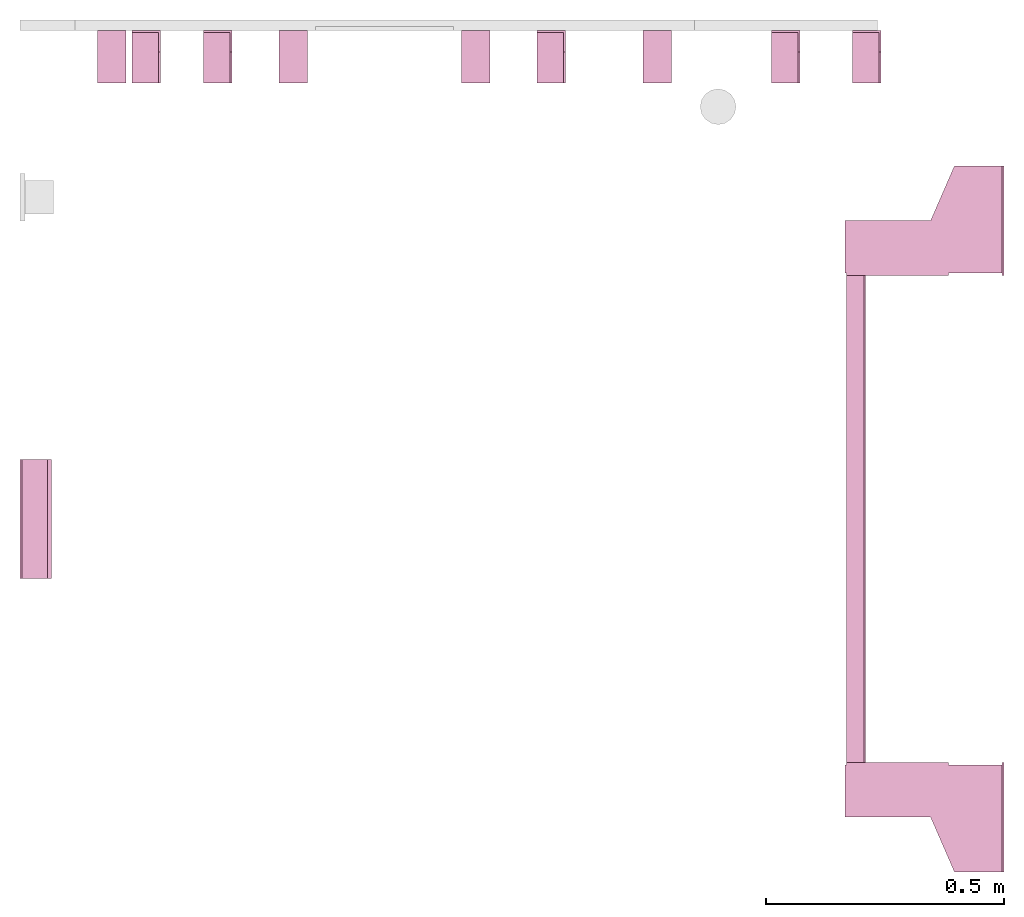
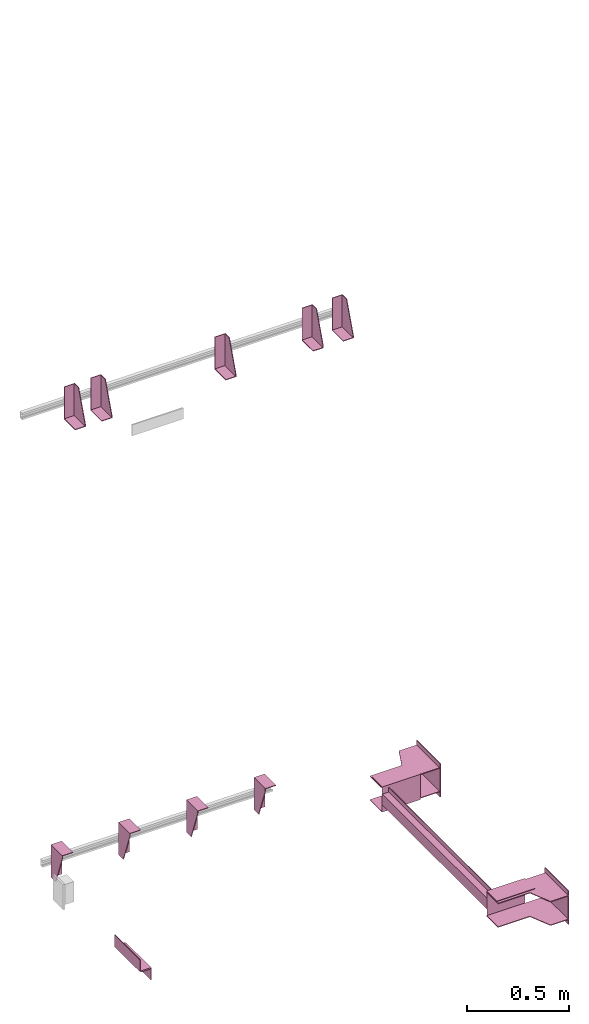
# One storey, part 3 of 3: 11 transport elements.
"""IFC4 building model written with IfcOpenShell, lengths in millimetres."""

from ifc_helpers import new_model, entity, si_unit, converted_unit, frame, origin_with_axes, place, context, subcontext, project, spatial, faceted_brep, element, save


model = new_model("IFC4")

# Units and contexts
context_of_model = context(None, 3, precision=0.01, world=origin_with_axes())
sub_context_1 = subcontext(context_of_model, None, None, "MODEL_VIEW")
sub_context_2 = subcontext(context_of_model, None, None, "MODEL_VIEW")
sub_context_3 = subcontext(context_of_model, None, None, "MODEL_VIEW")
sub_context_4 = subcontext(context_of_model, None, None, "MODEL_VIEW")
sub_context_5 = subcontext(context_of_model, None, None, "MODEL_VIEW")
sub_context_6 = subcontext(context_of_model, None, None, "MODEL_VIEW")
sub_context_7 = subcontext(context_of_model, None, None, "MODEL_VIEW")
sub_context_8 = subcontext(context_of_model, None, None, "MODEL_VIEW")
sub_context_9 = subcontext(context_of_model, None, None, "MODEL_VIEW")
sub_context_10 = subcontext(context_of_model, None, None, "MODEL_VIEW")
sub_context_11 = subcontext(context_of_model, None, None, "MODEL_VIEW")
ifc_project = project(units=[converted_unit("PLANEANGLEUNIT", "degree", entity("IfcPlaneAngleMeasure", 0.017453292519943), si_unit("PLANEANGLEUNIT", "RADIAN"), dimensions=[0, 0, 0, 0, 0, 0, 0]), si_unit("LENGTHUNIT", "METRE", prefix="MILLI"), si_unit("MASSUNIT", "GRAM", prefix="KILO"), converted_unit("TIMEUNIT", "year", entity("IfcTimeMeasure", 31557600.0), si_unit("TIMEUNIT", "SECOND"), dimensions=[0, 0, 1, 0, 0, 0, 0]), si_unit("THERMODYNAMICTEMPERATUREUNIT", "DEGREE_CELSIUS"), si_unit("AREAUNIT", "SQUARE_METRE"), si_unit("FORCEUNIT", "NEWTON"), si_unit("VOLUMEUNIT", "CUBIC_METRE"), si_unit("PRESSUREUNIT", "PASCAL"), si_unit("SOLIDANGLEUNIT", "STERADIAN")], contexts=[context_of_model])

# Site, building, storey
site = spatial("IfcSite", under=ifc_project)
building = spatial("IfcBuilding", under=site, Name="Document")
placement = place(None, origin_with_axes())
storey_placement = place(placement, frame((0.0, 0.0, -10200.0), z_axis=(0.0, 0.0, 1.0), x_axis=(1.0, 0.0, 0.0)))
storey = spatial("IfcBuildingStorey", under=building, at=storey_placement, Name="P1", Elevation=-10200.0)

# Transport elements
transport_element_1_placement = place(storey_placement, frame((2065.0, 1025.0, 0.0), z_axis=(0.0, 0.0, 1.0), x_axis=(0.0, 1.0, 0.0)))
element("IfcTransportElement", 1, at=transport_element_1_placement, inside=storey, PredefinedType="ELEVATOR", context=sub_context_1, shape_type="Brep", body=[
    faceted_brep([(-511.0, 331.0, 32.5), (511.0, 331.0, 32.5), (511.0, 331.0, -32.5), (-511.0, 331.0, -32.5), (511.0, 328.0, -29.5), (511.0, 328.0, 29.5), (-511.0, 328.0, 29.5), (-511.0, 328.0, -29.5), (511.0, 291.0, -32.5), (511.0, 291.0, -29.5), (-511.0, 291.0, -29.5), (-511.0, 291.0, -32.5), (511.0, 291.0, 29.5), (511.0, 291.0, 32.5), (-511.0, 291.0, 32.5), (-511.0, 291.0, 29.5)], [[[0, 1, 2, 3]], [[4, 5, 6, 7]], [[8, 9, 10, 11]], [[12, 13, 14, 15]], [[11, 10, 7, 6, 15, 14, 0, 3]], [[2, 1, 13, 12, 5, 4, 9, 8]], [[2, 8, 11, 3]], [[10, 9, 4, 7]], [[14, 13, 1, 0]], [[5, 12, 15, 6]]]),
    faceted_brep([(-511.0, 291.0, 59.5), (-511.0, 294.0, 59.5), (-511.0, 294.0, 32.5), (-511.0, 291.0, 32.5), (511.0, 291.0, 59.5), (511.0, 291.0, 32.5), (511.0, 294.0, 32.5), (511.0, 294.0, 59.5)], [[[0, 1, 2, 3]], [[4, 5, 6, 7]], [[0, 3, 5, 4]], [[3, 2, 6, 5]], [[2, 1, 7, 6]], [[1, 0, 4, 7]]]),
    faceted_brep([(-611.0, 331.0, -72.5), (-514.0, 331.0, -72.5), (-514.0, 331.0, 72.5), (-611.0, 331.0, 72.5), (-611.0, 331.0, 75.5), (-511.0, 331.0, 75.5), (-511.0, 331.0, -75.5), (-611.0, 331.0, -75.5), (-511.0, 116.0, -75.5), (-511.0, 116.0, 75.5), (-611.0, 116.0, 75.5), (-611.0, 116.0, 72.5), (-514.0, 116.0, 72.5), (-514.0, 116.0, -72.5), (-611.0, 116.0, -72.5), (-611.0, 116.0, -75.5)], [[[0, 1, 2, 3, 4, 5, 6, 7]], [[8, 9, 10, 11, 12, 13, 14, 15]], [[15, 14, 0, 7]], [[13, 12, 2, 1]], [[5, 9, 8, 6]], [[11, 10, 4, 3]], [[6, 8, 15, 7]], [[14, 13, 1, 0]], [[2, 12, 11, 3]], [[10, 9, 5, 4]]]),
    faceted_brep([(511.0, 331.0, 75.5), (611.0, 331.0, 75.5), (611.0, 331.0, 72.5), (514.0, 331.0, 72.5), (514.0, 331.0, -72.5), (611.0, 331.0, -72.5), (611.0, 331.0, -75.5), (511.0, 331.0, -75.5), (511.0, 116.0, -75.5), (611.0, 116.0, -75.5), (611.0, 116.0, -72.5), (514.0, 116.0, -72.5), (514.0, 116.0, 72.5), (611.0, 116.0, 72.5), (611.0, 116.0, 75.5), (511.0, 116.0, 75.5)], [[[0, 1, 2, 3, 4, 5, 6, 7]], [[8, 9, 10, 11, 12, 13, 14, 15]], [[8, 15, 0, 7]], [[3, 12, 11, 4]], [[5, 10, 9, 6]], [[1, 14, 13, 2]], [[6, 9, 8, 7]], [[11, 10, 5, 4]], [[15, 14, 1, 0]], [[2, 13, 12, 3]]]),
    faceted_brep([(-511.0, 291.0, -32.5), (-511.0, 294.0, -32.5), (-511.0, 294.0, -59.5), (-511.0, 291.0, -59.5), (511.0, 291.0, -32.5), (511.0, 291.0, -59.5), (511.0, 294.0, -59.5), (511.0, 294.0, -32.5)], [[[0, 1, 2, 3]], [[4, 5, 6, 7]], [[0, 3, 5, 4]], [[3, 2, 6, 5]], [[2, 1, 7, 6]], [[1, 0, 4, 7]]]),
    faceted_brep([(-626.0, 334.0, 72.5), (-516.0, 334.0, 72.5), (-516.0, 334.0, 68.5), (-626.0, 334.0, 68.5), (-516.0, 4.0, 68.5), (-516.0, 4.0, 72.5), (-741.0, 4.0, 72.5), (-741.0, 4.0, 68.5), (-741.0, 104.0, 72.5), (-626.0, 154.0, 72.5), (-626.0, 154.0, 68.5), (-741.0, 104.0, 68.5)], [[[0, 1, 2, 3]], [[4, 5, 6, 7]], [[8, 9, 10, 11]], [[10, 9, 0, 3]], [[1, 5, 4, 2]], [[7, 6, 8, 11]], [[2, 4, 7, 11, 10, 3]], [[9, 8, 6, 5, 1, 0]]]),
    faceted_brep([(516.0, 334.0, 72.5), (626.0, 334.0, 72.5), (626.0, 334.0, 68.5), (516.0, 334.0, 68.5), (741.0, 4.0, 68.5), (741.0, 4.0, 72.5), (516.0, 4.0, 72.5), (516.0, 4.0, 68.5), (626.0, 154.0, 72.5), (741.0, 104.0, 72.5), (741.0, 104.0, 68.5), (626.0, 154.0, 68.5)], [[[0, 1, 2, 3]], [[4, 5, 6, 7]], [[8, 9, 10, 11]], [[7, 6, 0, 3]], [[1, 8, 11, 2]], [[9, 5, 4, 10]], [[2, 11, 10, 4, 7, 3]], [[6, 5, 9, 8, 1, 0]]]),
    faceted_brep([(516.0, 334.0, -68.5), (626.0, 334.0, -68.5), (626.0, 334.0, -72.5), (516.0, 334.0, -72.5), (741.0, 4.0, -72.5), (741.0, 4.0, -68.5), (516.0, 4.0, -68.5), (516.0, 4.0, -72.5), (626.0, 154.0, -68.5), (741.0, 104.0, -68.5), (741.0, 104.0, -72.5), (626.0, 154.0, -72.5)], [[[0, 1, 2, 3]], [[4, 5, 6, 7]], [[8, 9, 10, 11]], [[7, 6, 0, 3]], [[1, 8, 11, 2]], [[9, 5, 4, 10]], [[2, 11, 10, 4, 7, 3]], [[6, 5, 9, 8, 1, 0]]]),
    faceted_brep([(-626.0, 334.0, -68.5), (-516.0, 334.0, -68.5), (-516.0, 334.0, -72.5), (-626.0, 334.0, -72.5), (-516.0, 4.0, -72.5), (-516.0, 4.0, -68.5), (-741.0, 4.0, -68.5), (-741.0, 4.0, -72.5), (-741.0, 104.0, -68.5), (-626.0, 154.0, -68.5), (-626.0, 154.0, -72.5), (-741.0, 104.0, -72.5)], [[[0, 1, 2, 3]], [[4, 5, 6, 7]], [[8, 9, 10, 11]], [[10, 9, 0, 3]], [[1, 5, 4, 2]], [[7, 6, 8, 11]], [[2, 4, 7, 11, 10, 3]], [[9, 8, 6, 5, 1, 0]]]),
    faceted_brep([(741.0, 0.0, -100.0), (741.0, 0.0, 100.0), (511.0, 0.0, 100.0), (511.0, 0.0, -100.0), (741.0, 4.0, -100.0), (511.0, 4.0, -100.0), (511.0, 4.0, 100.0), (741.0, 4.0, 100.0)], [[[0, 1, 2, 3]], [[4, 5, 6, 7]], [[0, 3, 5, 4]], [[3, 2, 6, 5]], [[2, 1, 7, 6]], [[1, 0, 4, 7]]]),
    faceted_brep([(-511.0, 0.0, -100.0), (-511.0, 0.0, 100.0), (-741.0, 0.0, 100.0), (-741.0, 0.0, -100.0), (-511.0, 4.0, -100.0), (-741.0, 4.0, -100.0), (-741.0, 4.0, 100.0), (-511.0, 4.0, 100.0)], [[[0, 1, 2, 3]], [[4, 5, 6, 7]], [[0, 3, 5, 4]], [[3, 2, 6, 5]], [[2, 1, 7, 6]], [[1, 0, 4, 7]]]),
])
transport_element_2_placement = place(storey_placement, frame((1777.0, 2050.0, 2580.0), z_axis=(0.0, 0.0, 1.0), x_axis=(-1.0, 0.0, 0.0)))
element("IfcTransportElement", 2, at=transport_element_2_placement, inside=storey, PredefinedType="ELEVATOR", context=sub_context_2, shape_type="Brep", body=[
    faceted_brep([(30.0, 110.0, -93.0), (30.0, 4.0, -93.0), (30.0, 4.0, 97.0), (30.0, 0.0, 97.0), (30.0, 0.0, -97.0), (30.0, 110.0, -97.0), (-30.0, 0.0, -97.0), (-30.0, 0.0, 97.0), (-30.0, 4.0, 97.0), (-30.0, 4.0, -93.0), (-30.0, 110.0, -93.0), (-30.0, 110.0, -97.0)], [[[0, 1, 2, 3, 4, 5]], [[6, 7, 8, 9, 10, 11]], [[11, 10, 0, 5]], [[9, 8, 2, 1]], [[3, 7, 6, 4]], [[4, 6, 11, 5]], [[10, 9, 1, 0]], [[8, 7, 3, 2]]]),
    faceted_brep([(-30.0, 4.0, -93.0), (-30.0, 4.0, 97.0), (-30.0, 45.0, 97.0), (-30.0, 110.0, -82.0), (-30.0, 110.0, -93.0), (-26.0, 4.0, -93.0), (-26.0, 110.0, -93.0), (-26.0, 110.0, -82.0), (-26.0, 45.0, 97.0), (-26.0, 4.0, 97.0)], [[[0, 1, 2, 3, 4]], [[5, 6, 7, 8, 9]], [[5, 0, 4, 6]], [[6, 4, 3, 7]], [[7, 3, 2, 8]], [[8, 2, 1, 9]], [[9, 1, 0, 5]]]),
])
transport_element_3_placement = place(storey_placement, frame((1607.0, 2050.0, 2580.0), z_axis=(0.0, 0.0, 1.0), x_axis=(-1.0, 0.0, 0.0)))
element("IfcTransportElement", 3, at=transport_element_3_placement, inside=storey, PredefinedType="ELEVATOR", context=sub_context_3, shape_type="Brep", body=[
    faceted_brep([(30.0, 110.0, -93.0), (30.0, 4.0, -93.0), (30.0, 4.0, 97.0), (30.0, 0.0, 97.0), (30.0, 0.0, -97.0), (30.0, 110.0, -97.0), (-30.0, 0.0, -97.0), (-30.0, 0.0, 97.0), (-30.0, 4.0, 97.0), (-30.0, 4.0, -93.0), (-30.0, 110.0, -93.0), (-30.0, 110.0, -97.0)], [[[0, 1, 2, 3, 4, 5]], [[6, 7, 8, 9, 10, 11]], [[11, 10, 0, 5]], [[9, 8, 2, 1]], [[3, 7, 6, 4]], [[4, 6, 11, 5]], [[10, 9, 1, 0]], [[8, 7, 3, 2]]]),
    faceted_brep([(-30.0, 4.0, -93.0), (-30.0, 4.0, 97.0), (-30.0, 45.0, 97.0), (-30.0, 110.0, -82.0), (-30.0, 110.0, -93.0), (-26.0, 4.0, -93.0), (-26.0, 110.0, -93.0), (-26.0, 110.0, -82.0), (-26.0, 45.0, 97.0), (-26.0, 4.0, 97.0)], [[[0, 1, 2, 3, 4]], [[5, 6, 7, 8, 9]], [[5, 0, 4, 6]], [[6, 4, 3, 7]], [[7, 3, 2, 8]], [[8, 2, 1, 9]], [[9, 1, 0, 5]]]),
])
transport_element_4_placement = place(storey_placement, frame((1115.0, 2050.0, 2580.0), z_axis=(0.0, 0.0, 1.0), x_axis=(-1.0, 0.0, 0.0)))
element("IfcTransportElement", 4, at=transport_element_4_placement, inside=storey, PredefinedType="ELEVATOR", context=sub_context_4, shape_type="Brep", body=[
    faceted_brep([(30.0, 110.0, -93.0), (30.0, 4.0, -93.0), (30.0, 4.0, 97.0), (30.0, 0.0, 97.0), (30.0, 0.0, -97.0), (30.0, 110.0, -97.0), (-30.0, 0.0, -97.0), (-30.0, 0.0, 97.0), (-30.0, 4.0, 97.0), (-30.0, 4.0, -93.0), (-30.0, 110.0, -93.0), (-30.0, 110.0, -97.0)], [[[0, 1, 2, 3, 4, 5]], [[6, 7, 8, 9, 10, 11]], [[11, 10, 0, 5]], [[9, 8, 2, 1]], [[3, 7, 6, 4]], [[4, 6, 11, 5]], [[10, 9, 1, 0]], [[8, 7, 3, 2]]]),
    faceted_brep([(-30.0, 4.0, -93.0), (-30.0, 4.0, 97.0), (-30.0, 45.0, 97.0), (-30.0, 110.0, -82.0), (-30.0, 110.0, -93.0), (-26.0, 4.0, -93.0), (-26.0, 110.0, -93.0), (-26.0, 110.0, -82.0), (-26.0, 45.0, 97.0), (-26.0, 4.0, 97.0)], [[[0, 1, 2, 3, 4]], [[5, 6, 7, 8, 9]], [[5, 0, 4, 6]], [[6, 4, 3, 7]], [[7, 3, 2, 8]], [[8, 2, 1, 9]], [[9, 1, 0, 5]]]),
])
transport_element_5_placement = place(storey_placement, frame((415.0, 2050.0, 2580.0), z_axis=(0.0, 0.0, 1.0), x_axis=(-1.0, 0.0, 0.0)))
element("IfcTransportElement", 5, at=transport_element_5_placement, inside=storey, PredefinedType="ELEVATOR", context=sub_context_5, shape_type="Brep", body=[
    faceted_brep([(-30.0, 4.0, -93.0), (-30.0, 4.0, 97.0), (-30.0, 45.0, 97.0), (-30.0, 110.0, -82.0), (-30.0, 110.0, -93.0), (-26.0, 4.0, -93.0), (-26.0, 110.0, -93.0), (-26.0, 110.0, -82.0), (-26.0, 45.0, 97.0), (-26.0, 4.0, 97.0)], [[[0, 1, 2, 3, 4]], [[5, 6, 7, 8, 9]], [[5, 0, 4, 6]], [[6, 4, 3, 7]], [[7, 3, 2, 8]], [[8, 2, 1, 9]], [[9, 1, 0, 5]]]),
    faceted_brep([(30.0, 110.0, -93.0), (30.0, 4.0, -93.0), (30.0, 4.0, 97.0), (30.0, 0.0, 97.0), (30.0, 0.0, -97.0), (30.0, 110.0, -97.0), (-30.0, 0.0, -97.0), (-30.0, 0.0, 97.0), (-30.0, 4.0, 97.0), (-30.0, 4.0, -93.0), (-30.0, 110.0, -93.0), (-30.0, 110.0, -97.0)], [[[0, 1, 2, 3, 4, 5]], [[6, 7, 8, 9, 10, 11]], [[11, 10, 0, 5]], [[9, 8, 2, 1]], [[3, 7, 6, 4]], [[4, 6, 11, 5]], [[10, 9, 1, 0]], [[8, 7, 3, 2]]]),
])
transport_element_6_placement = place(storey_placement, frame((265.0, 2050.0, 2580.0), z_axis=(0.0, 0.0, 1.0), x_axis=(-1.0, 0.0, 0.0)))
element("IfcTransportElement", 6, at=transport_element_6_placement, inside=storey, PredefinedType="ELEVATOR", context=sub_context_6, shape_type="Brep", body=[
    faceted_brep([(30.0, 110.0, -93.0), (30.0, 4.0, -93.0), (30.0, 4.0, 97.0), (30.0, 0.0, 97.0), (30.0, 0.0, -97.0), (30.0, 110.0, -97.0), (-30.0, 0.0, -97.0), (-30.0, 0.0, 97.0), (-30.0, 4.0, 97.0), (-30.0, 4.0, -93.0), (-30.0, 110.0, -93.0), (-30.0, 110.0, -97.0)], [[[0, 1, 2, 3, 4, 5]], [[6, 7, 8, 9, 10, 11]], [[11, 10, 0, 5]], [[9, 8, 2, 1]], [[3, 7, 6, 4]], [[4, 6, 11, 5]], [[10, 9, 1, 0]], [[8, 7, 3, 2]]]),
    faceted_brep([(-30.0, 4.0, -93.0), (-30.0, 4.0, 97.0), (-30.0, 45.0, 97.0), (-30.0, 110.0, -82.0), (-30.0, 110.0, -93.0), (-26.0, 4.0, -93.0), (-26.0, 110.0, -93.0), (-26.0, 110.0, -82.0), (-26.0, 45.0, 97.0), (-26.0, 4.0, 97.0)], [[[0, 1, 2, 3, 4]], [[5, 6, 7, 8, 9]], [[5, 0, 4, 6]], [[6, 4, 3, 7]], [[7, 3, 2, 8]], [[8, 2, 1, 9]], [[9, 1, 0, 5]]]),
])
transport_element_7_placement = place(storey_placement, frame((192.5, 2050.0, -30.0), z_axis=(0.0, 0.0, -1.0), x_axis=(1.0, 0.0, 0.0)))
element("IfcTransportElement", 7, at=transport_element_7_placement, inside=storey, PredefinedType="ELEVATOR", context=sub_context_7, shape_type="Brep", body=[
    faceted_brep([(-30.0, 4.0, 4.0), (-30.0, 110.0, 4.0), (-30.0, 110.0, 0.0), (-30.0, 0.0, 0.0), (-30.0, 0.0, 194.0), (-30.0, 4.0, 194.0), (30.0, 0.0, 194.0), (30.0, 0.0, 0.0), (30.0, 110.0, 0.0), (30.0, 110.0, 4.0), (30.0, 4.0, 4.0), (30.0, 4.0, 194.0)], [[[0, 1, 2, 3, 4, 5]], [[6, 7, 8, 9, 10, 11]], [[11, 10, 0, 5]], [[3, 7, 6, 4]], [[9, 8, 2, 1]], [[4, 6, 11, 5]], [[0, 10, 9, 1]], [[8, 7, 3, 2]]]),
    faceted_brep([(-30.0, 4.0, 4.0), (-30.0, 4.0, 194.0), (-30.0, 45.0, 194.0), (-30.0, 110.0, 15.0), (-30.0, 110.0, 4.0), (-26.0, 4.0, 4.0), (-26.0, 110.0, 4.0), (-26.0, 110.0, 15.0), (-26.0, 45.0, 194.0), (-26.0, 4.0, 194.0)], [[[0, 1, 2, 3, 4]], [[5, 6, 7, 8, 9]], [[5, 0, 4, 6]], [[6, 4, 3, 7]], [[7, 3, 2, 8]], [[8, 2, 1, 9]], [[9, 1, 0, 5]]]),
])
transport_element_8_placement = place(storey_placement, frame((573.84, 2050.0, -30.0), z_axis=(0.0, 0.0, -1.0), x_axis=(1.0, 0.0, 0.0)))
element("IfcTransportElement", 8, at=transport_element_8_placement, inside=storey, PredefinedType="ELEVATOR", context=sub_context_8, shape_type="Brep", body=[
    faceted_brep([(-29.999973144531282, 4.0, 4.0), (-29.999973144531282, 110.0, 4.0), (-29.999973144531282, 110.0, 0.0), (-29.999973144531282, 0.0, 0.0), (-29.999973144531282, 0.0, 194.0), (-29.999973144531282, 4.0, 194.0), (30.000026855468718, 0.0, 194.0), (30.000026855468718, 0.0, 0.0), (30.000026855468718, 110.0, 0.0), (30.000026855468718, 110.0, 4.0), (30.000026855468718, 4.0, 4.0), (30.000026855468718, 4.0, 194.0)], [[[0, 1, 2, 3, 4, 5]], [[6, 7, 8, 9, 10, 11]], [[11, 10, 0, 5]], [[3, 7, 6, 4]], [[9, 8, 2, 1]], [[4, 6, 11, 5]], [[0, 10, 9, 1]], [[8, 7, 3, 2]]]),
    faceted_brep([(-29.999973144531282, 4.0, 4.0), (-29.999973144531282, 4.0, 194.0), (-29.999973144531282, 45.0, 194.0), (-29.999973144531282, 110.0, 15.0), (-29.999973144531282, 110.0, 4.0), (-25.999973144531282, 4.0, 4.0), (-25.999973144531282, 110.0, 4.0), (-25.999973144531282, 110.0, 15.0), (-25.999973144531282, 45.0, 194.0), (-25.999973144531282, 4.0, 194.0)], [[[0, 1, 2, 3, 4]], [[5, 6, 7, 8, 9]], [[5, 0, 4, 6]], [[6, 4, 3, 7]], [[7, 3, 2, 8]], [[8, 2, 1, 9]], [[9, 1, 0, 5]]]),
])
transport_element_9_placement = place(storey_placement, frame((956.16, 2050.0, -30.0), z_axis=(0.0, 0.0, -1.0), x_axis=(1.0, 0.0, 0.0)))
element("IfcTransportElement", 9, at=transport_element_9_placement, inside=storey, PredefinedType="ELEVATOR", context=sub_context_9, shape_type="Brep", body=[
    faceted_brep([(-30.000026855468718, 4.0, 4.0), (-30.000026855468718, 4.0, 194.0), (-30.000026855468718, 45.0, 194.0), (-30.000026855468718, 110.0, 15.0), (-30.000026855468718, 110.0, 4.0), (-26.000026855468718, 4.0, 4.0), (-26.000026855468718, 110.0, 4.0), (-26.000026855468718, 110.0, 15.0), (-26.000026855468718, 45.0, 194.0), (-26.000026855468718, 4.0, 194.0)], [[[0, 1, 2, 3, 4]], [[5, 6, 7, 8, 9]], [[5, 0, 4, 6]], [[6, 4, 3, 7]], [[7, 3, 2, 8]], [[8, 2, 1, 9]], [[9, 1, 0, 5]]]),
    faceted_brep([(-30.000026855468718, 4.0, 4.0), (-30.000026855468718, 110.0, 4.0), (-30.000026855468718, 110.0, 0.0), (-30.000026855468718, 0.0, 0.0), (-30.000026855468718, 0.0, 194.0), (-30.000026855468718, 4.0, 194.0), (29.999973144531282, 0.0, 194.0), (29.999973144531282, 0.0, 0.0), (29.999973144531282, 110.0, 0.0), (29.999973144531282, 110.0, 4.0), (29.999973144531282, 4.0, 4.0), (29.999973144531282, 4.0, 194.0)], [[[0, 1, 2, 3, 4, 5]], [[6, 7, 8, 9, 10, 11]], [[11, 10, 0, 5]], [[3, 7, 6, 4]], [[9, 8, 2, 1]], [[4, 6, 11, 5]], [[0, 10, 9, 1]], [[8, 7, 3, 2]]]),
])
transport_element_10_placement = place(storey_placement, frame((1337.5, 2050.0, -30.0), z_axis=(0.0, 0.0, -1.0), x_axis=(1.0, 0.0, 0.0)))
element("IfcTransportElement", 10, at=transport_element_10_placement, inside=storey, PredefinedType="ELEVATOR", context=sub_context_10, shape_type="Brep", body=[
    faceted_brep([(-30.0, 4.0, 4.0), (-30.0, 110.0, 4.0), (-30.0, 110.0, 0.0), (-30.0, 0.0, 0.0), (-30.0, 0.0, 194.0), (-30.0, 4.0, 194.0), (30.0, 0.0, 194.0), (30.0, 0.0, 0.0), (30.0, 110.0, 0.0), (30.0, 110.0, 4.0), (30.0, 4.0, 4.0), (30.0, 4.0, 194.0)], [[[0, 1, 2, 3, 4, 5]], [[6, 7, 8, 9, 10, 11]], [[11, 10, 0, 5]], [[3, 7, 6, 4]], [[9, 8, 2, 1]], [[4, 6, 11, 5]], [[0, 10, 9, 1]], [[8, 7, 3, 2]]]),
    faceted_brep([(-30.0, 4.0, 4.0), (-30.0, 4.0, 194.0), (-30.0, 45.0, 194.0), (-30.0, 110.0, 15.0), (-30.0, 110.0, 4.0), (-26.0, 4.0, 4.0), (-26.0, 110.0, 4.0), (-26.0, 110.0, 15.0), (-26.0, 45.0, 194.0), (-26.0, 4.0, 194.0)], [[[0, 1, 2, 3, 4]], [[5, 6, 7, 8, 9]], [[5, 0, 4, 6]], [[6, 4, 3, 7]], [[7, 3, 2, 8]], [[8, 2, 1, 9]], [[9, 1, 0, 5]]]),
])
transport_element_11_placement = place(storey_placement, frame((0.0, 1025.0, 0.0), z_axis=(0.0, 0.0, 1.0), x_axis=(0.0, -1.0, 0.0)))
element("IfcTransportElement", 11, at=transport_element_11_placement, inside=storey, PredefinedType="ELEVATOR", context=sub_context_11, shape_type="Brep", body=[
    faceted_brep([(125.0, 8.0, -35.0), (-125.0, 8.0, -35.0), (-125.0, 8.0, -39.0), (125.0, 8.0, -39.0), (125.0, 62.0, -39.0), (-125.0, 62.0, -39.0), (-125.0, 62.0, -105.0), (125.0, 62.0, -105.0), (-125.0, 66.0, -105.0), (-125.0, 66.0, -35.0), (125.0, 66.0, -35.0), (125.0, 66.0, -105.0)], [[[0, 1, 2, 3]], [[4, 5, 6, 7]], [[8, 9, 10, 11]], [[4, 7, 11, 10, 0, 3]], [[1, 9, 8, 6, 5, 2]], [[2, 5, 4, 3]], [[10, 9, 1, 0]], [[6, 8, 11, 7]]]),
    faceted_brep([(125.0, 0.0, 35.0), (-125.0, 0.0, 35.0), (-125.0, 0.0, -35.0), (125.0, 0.0, -35.0), (-125.0, 4.0, -31.0), (-125.0, 4.0, 35.0), (125.0, 4.0, 35.0), (125.0, 4.0, -31.0), (-125.0, 58.0, -35.0), (-125.0, 58.0, -31.0), (125.0, 58.0, -31.0), (125.0, 58.0, -35.0)], [[[0, 1, 2, 3]], [[4, 5, 6, 7]], [[8, 9, 10, 11]], [[11, 10, 7, 6, 0, 3]], [[2, 1, 5, 4, 9, 8]], [[2, 8, 11, 3]], [[10, 9, 4, 7]], [[6, 5, 1, 0]]]),
])

save(model, "model.ifc")
